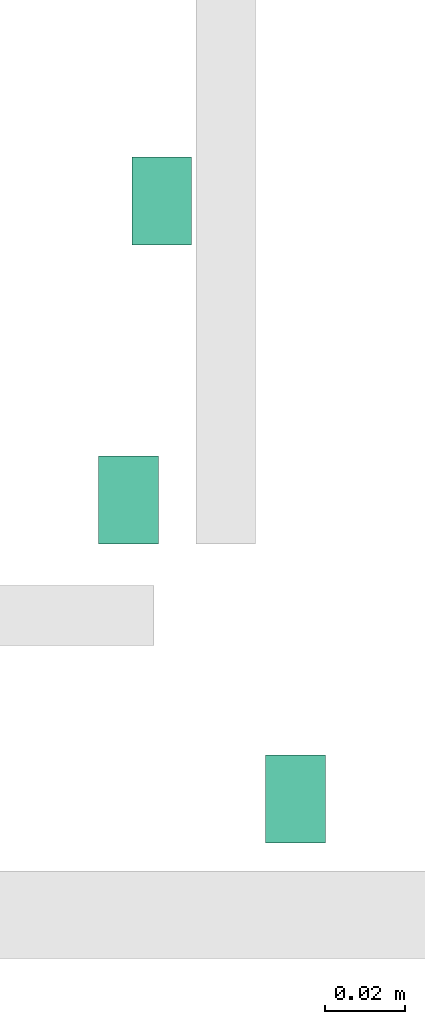
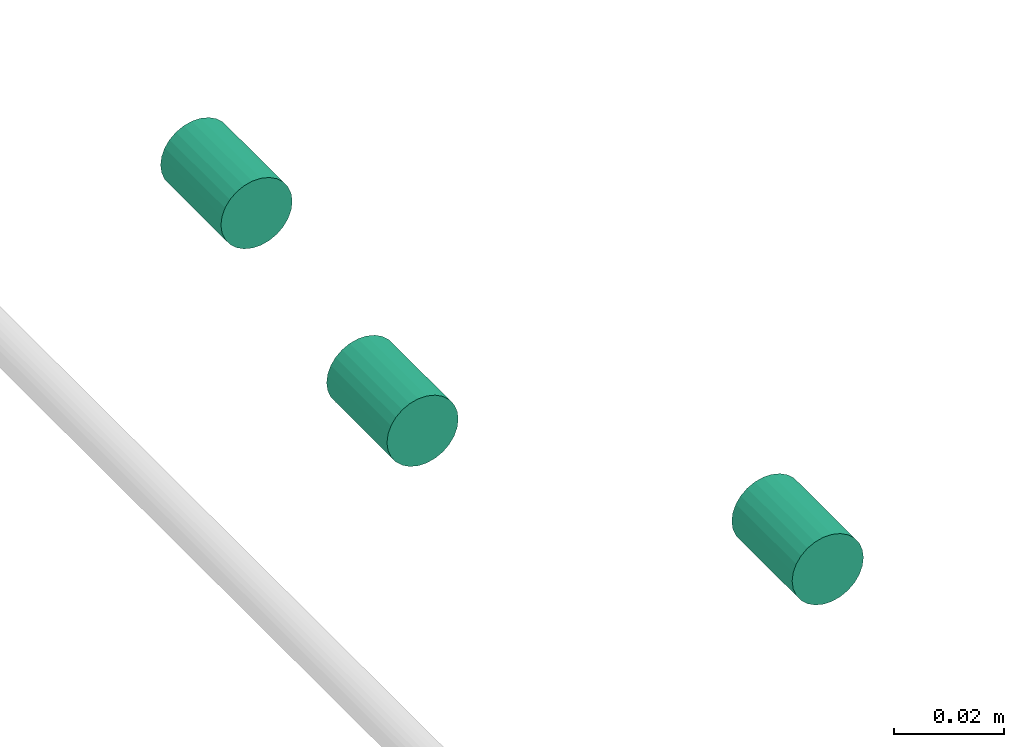
# One storey, part 302 of 331: 3 flow segments.
"""IFC2X3 building model written with IfcOpenShell, lengths in millimetres."""

from ifc_helpers import new_model, entity, si_unit, converted_unit, derived_unit, direction, frame, frame_2d, origin, origin_2d_with_axis, place, context, subcontext, project, spatial, circle, extrude, type_object, element, save


model = new_model("IFC2X3")

# Units and contexts
model_context = context("Model", 3, precision=0.01, world=origin(), true_north=direction((6.12303176911189e-17, 1.0)))
body_context = subcontext(model_context, "Body", "Model", "MODEL_VIEW")
ifc_project = project(units=[si_unit("LENGTHUNIT", "METRE", prefix="MILLI"), si_unit("AREAUNIT", "SQUARE_METRE"), si_unit("VOLUMEUNIT", "CUBIC_METRE"), converted_unit("PLANEANGLEUNIT", "DEGREE", entity("IfcRatioMeasure", 0.0174532925199433), si_unit("PLANEANGLEUNIT", "RADIAN"), dimensions=[0, 0, 0, 0, 0, 0, 0]), si_unit("MASSUNIT", "GRAM", prefix="KILO"), derived_unit("MASSDENSITYUNIT", [(si_unit("MASSUNIT", "GRAM", prefix="KILO"), 1), (si_unit("LENGTHUNIT", "METRE"), -3)]), derived_unit("MOMENTOFINERTIAUNIT", [(si_unit("LENGTHUNIT", "METRE"), 4)]), si_unit("TIMEUNIT", "SECOND"), si_unit("FREQUENCYUNIT", "HERTZ"), si_unit("THERMODYNAMICTEMPERATUREUNIT", "DEGREE_CELSIUS"), derived_unit("THERMALTRANSMITTANCEUNIT", [(si_unit("MASSUNIT", "GRAM", prefix="KILO"), 1), (si_unit("THERMODYNAMICTEMPERATUREUNIT", "KELVIN"), -1), (si_unit("TIMEUNIT", "SECOND"), -3)]), derived_unit("VOLUMETRICFLOWRATEUNIT", [(si_unit("LENGTHUNIT", "METRE"), 3), (si_unit("TIMEUNIT", "SECOND"), -1)]), derived_unit("MASSFLOWRATEUNIT", [(si_unit("MASSUNIT", "GRAM", prefix="KILO"), 1), (si_unit("TIMEUNIT", "SECOND"), -1)]), derived_unit("ROTATIONALFREQUENCYUNIT", [(si_unit("TIMEUNIT", "SECOND"), -1)]), si_unit("ELECTRICCURRENTUNIT", "AMPERE"), si_unit("ELECTRICVOLTAGEUNIT", "VOLT"), si_unit("POWERUNIT", "WATT"), si_unit("FORCEUNIT", "NEWTON", prefix="KILO"), si_unit("ILLUMINANCEUNIT", "LUX"), si_unit("LUMINOUSFLUXUNIT", "LUMEN"), si_unit("LUMINOUSINTENSITYUNIT", "CANDELA"), derived_unit("USERDEFINED", [(si_unit("MASSUNIT", "GRAM", prefix="KILO"), -1), (si_unit("LENGTHUNIT", "METRE"), -2), (si_unit("TIMEUNIT", "SECOND"), 3), (si_unit("LUMINOUSFLUXUNIT", "LUMEN"), 1)]), derived_unit("LINEARVELOCITYUNIT", [(si_unit("LENGTHUNIT", "METRE"), 1), (si_unit("TIMEUNIT", "SECOND"), -1)]), si_unit("PRESSUREUNIT", "PASCAL"), derived_unit("USERDEFINED", [(si_unit("LENGTHUNIT", "METRE"), -2), (si_unit("MASSUNIT", "GRAM", prefix="KILO"), 1), (si_unit("TIMEUNIT", "SECOND"), -2)]), derived_unit("LINEARFORCEUNIT", [(si_unit("MASSUNIT", "GRAM", prefix="KILO"), 1), (si_unit("LENGTHUNIT", "METRE"), 1), (si_unit("TIMEUNIT", "SECOND"), -2), (si_unit("LENGTHUNIT", "METRE"), -1)]), derived_unit("PLANARFORCEUNIT", [(si_unit("MASSUNIT", "GRAM", prefix="KILO"), 1), (si_unit("LENGTHUNIT", "METRE"), 1), (si_unit("TIMEUNIT", "SECOND"), -2), (si_unit("LENGTHUNIT", "METRE"), -2)])], contexts=[model_context])

# Site, building, storey
site_placement = place(None, frame((0.0, -0.00077364408347762, 0.0)))
site = spatial("IfcSite", under=ifc_project, at=site_placement, CompositionType="ELEMENT")
building_placement = place(site_placement, origin())
building = spatial("IfcBuilding", under=site, at=building_placement, CompositionType="ELEMENT")
storey_placement = place(building_placement, origin())
storey = spatial("IfcBuildingStorey", under=building, at=storey_placement, CompositionType="ELEMENT", Elevation=0.0)

# Flow segments
pipe_segment_type = type_object("IfcPipeSegmentType", PredefinedType="NOTDEFINED")
for number, where in (
    (1, (62271.0296911874, 9868.0, 6672.97579557594)),
    (2, (62262.6572439149, 9793.0, 6672.97579557594)),
):
    element("IfcFlowSegment", number, at=place(building_placement, frame(where)), inside=storey, type_object=pipe_segment_type, context=body_context, shape_type="SweptSolid", body=[
        extrude(circle(Radius=7.5, at=origin_2d_with_axis()), frame((9.09527223591419, 0.0, 9.09527223591636), z_axis=(0.0, 1.0, 0.0), x_axis=(1.0, 0.0, 0.0)), (0.0, 0.0, 1.0), 22.0000000000037),
    ])
flow_segment_placement = place(building_placement, frame((62304.5988700963, 9718.0, 6672.97579557594)))
element("IfcFlowSegment", 3, at=flow_segment_placement, inside=storey, type_object=pipe_segment_type, context=body_context, shape_type="SweptSolid", body=[
    extrude(circle(Radius=7.5, at=frame_2d((-8.66293703438714e-12, 0.0), x_axis=(1.0, 0.0))), frame((9.09527223592286, 0.0, 9.09527223591636), z_axis=(0.0, 1.0, 0.0), x_axis=(1.0, 0.0, 0.0)), (0.0, 0.0, 1.0), 22.0000000000037),
])

save(model, "model.ifc")
